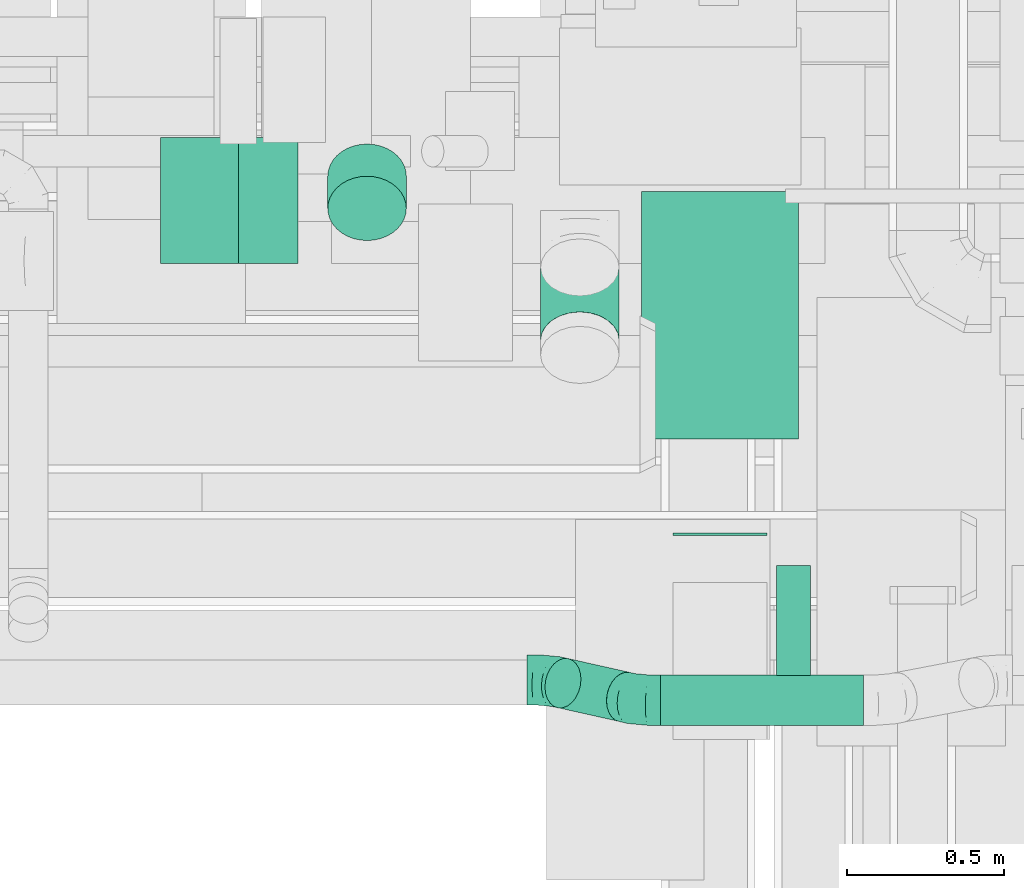
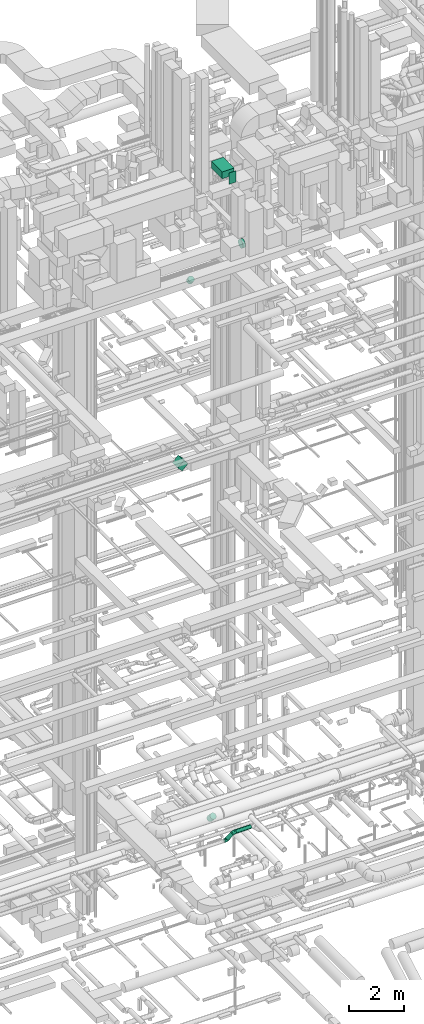
# One storey, part 180 of 337: 8 flow segments, 2 flow fittings.
"""IFC2X3 building model written with IfcOpenShell, lengths in millimetres."""

from ifc_helpers import new_model, entity, si_unit, converted_unit, derived_unit, direction, frame, frame_2d, origin, origin_2d_with_axis, place, context, subcontext, project, spatial, rectangle, circle, extrude, faceted_brep, source, transform, mapped, material, type_object, type_shapes, element, save


model = new_model("IFC2X3")

# Units and contexts
model_context = context("Model", 3, precision=0.01, world=origin(), true_north=direction((6.12303176911189e-17, 1.0)))
body_context = subcontext(model_context, "Body", "Model", "MODEL_VIEW")
ifc_project = project(units=[si_unit("LENGTHUNIT", "METRE", prefix="MILLI"), si_unit("AREAUNIT", "SQUARE_METRE"), si_unit("VOLUMEUNIT", "CUBIC_METRE"), converted_unit("PLANEANGLEUNIT", "DEGREE", entity("IfcRatioMeasure", 0.0174532925199433), si_unit("PLANEANGLEUNIT", "RADIAN"), dimensions=[0, 0, 0, 0, 0, 0, 0]), si_unit("MASSUNIT", "GRAM", prefix="KILO"), derived_unit("MASSDENSITYUNIT", [(si_unit("MASSUNIT", "GRAM", prefix="KILO"), 1), (si_unit("LENGTHUNIT", "METRE"), -3)]), derived_unit("MOMENTOFINERTIAUNIT", [(si_unit("LENGTHUNIT", "METRE"), 4)]), si_unit("TIMEUNIT", "SECOND"), si_unit("FREQUENCYUNIT", "HERTZ"), si_unit("THERMODYNAMICTEMPERATUREUNIT", "DEGREE_CELSIUS"), derived_unit("THERMALTRANSMITTANCEUNIT", [(si_unit("MASSUNIT", "GRAM", prefix="KILO"), 1), (si_unit("THERMODYNAMICTEMPERATUREUNIT", "KELVIN"), -1), (si_unit("TIMEUNIT", "SECOND"), -3)]), derived_unit("VOLUMETRICFLOWRATEUNIT", [(si_unit("LENGTHUNIT", "METRE"), 3), (si_unit("TIMEUNIT", "SECOND"), -1)]), derived_unit("MASSFLOWRATEUNIT", [(si_unit("MASSUNIT", "GRAM", prefix="KILO"), 1), (si_unit("TIMEUNIT", "SECOND"), -1)]), derived_unit("ROTATIONALFREQUENCYUNIT", [(si_unit("TIMEUNIT", "SECOND"), -1)]), si_unit("ELECTRICCURRENTUNIT", "AMPERE"), si_unit("ELECTRICVOLTAGEUNIT", "VOLT"), si_unit("POWERUNIT", "WATT"), si_unit("FORCEUNIT", "NEWTON", prefix="KILO"), si_unit("ILLUMINANCEUNIT", "LUX"), si_unit("LUMINOUSFLUXUNIT", "LUMEN"), si_unit("LUMINOUSINTENSITYUNIT", "CANDELA"), derived_unit("USERDEFINED", [(si_unit("MASSUNIT", "GRAM", prefix="KILO"), -1), (si_unit("LENGTHUNIT", "METRE"), -2), (si_unit("TIMEUNIT", "SECOND"), 3), (si_unit("LUMINOUSFLUXUNIT", "LUMEN"), 1)]), derived_unit("LINEARVELOCITYUNIT", [(si_unit("LENGTHUNIT", "METRE"), 1), (si_unit("TIMEUNIT", "SECOND"), -1)]), si_unit("PRESSUREUNIT", "PASCAL"), derived_unit("USERDEFINED", [(si_unit("LENGTHUNIT", "METRE"), -2), (si_unit("MASSUNIT", "GRAM", prefix="KILO"), 1), (si_unit("TIMEUNIT", "SECOND"), -2)]), derived_unit("LINEARFORCEUNIT", [(si_unit("MASSUNIT", "GRAM", prefix="KILO"), 1), (si_unit("LENGTHUNIT", "METRE"), 1), (si_unit("TIMEUNIT", "SECOND"), -2), (si_unit("LENGTHUNIT", "METRE"), -1)]), derived_unit("PLANARFORCEUNIT", [(si_unit("MASSUNIT", "GRAM", prefix="KILO"), 1), (si_unit("LENGTHUNIT", "METRE"), 1), (si_unit("TIMEUNIT", "SECOND"), -2), (si_unit("LENGTHUNIT", "METRE"), -2)])], contexts=[model_context])

# Site, building, storey
site_placement = place(None, origin())
site = spatial("IfcSite", under=ifc_project, at=site_placement, CompositionType="ELEMENT")
building_placement = place(site_placement, origin())
building = spatial("IfcBuilding", under=site, at=building_placement, CompositionType="ELEMENT")
storey_placement = place(building_placement, origin())
storey = spatial("IfcBuildingStorey", under=building, at=storey_placement, CompositionType="ELEMENT", Elevation=0.0)

# Flow segments
duct_segment_type_1 = type_object("IfcDuctSegmentType", PredefinedType="NOTDEFINED")
flow_segment_1_placement = place(storey_placement, frame((47985.48, 9525.31, 18766.45)))
element("IfcFlowSegment", 1, at=flow_segment_1_placement, inside=storey, type_object=duct_segment_type_1, context=body_context, shape_type="SweptSolid", body=[
    extrude(rectangle(XDim=350.0, YDim=268.162338159304, at=frame_2d((0.0, 0.0), x_axis=(0.0, 1.0))), frame((218.55, 0.0, 218.55), z_axis=(0.0, 1.0, 0.0), x_axis=(0.707106781186604, 0.0, -0.707106781186491)), (0.0, 0.0, 1.0), 400.0),
])
flow_segment_2_placement = place(storey_placement, frame((49515.11, 8966.84, 31500.0)))
element("IfcFlowSegment", 2, at=flow_segment_2_placement, inside=storey, type_object=duct_segment_type_1, context=body_context, shape_type="SweptSolid", body=[
    extrude(rectangle(XDim=787.000000000107, YDim=499.999999999999, at=origin_2d_with_axis()), frame((250.0, 393.5, 0.0), z_axis=(0.0, 0.0, 1.0), x_axis=(0.0, 1.0, 0.0)), (0.0, 0.0, 1.0), 300.000000000001),
])
flow_segment_3_placement = place(storey_placement, frame((49615.11, 8660.0, 31400.0)))
element("IfcFlowSegment", 3, at=flow_segment_3_placement, inside=storey, type_object=duct_segment_type_1, context=body_context, shape_type="SweptSolid", body=[
    extrude(rectangle(XDim=6.83947999997308, YDim=300.000000000001, at=origin_2d_with_axis()), frame((150.0, 3.42, 0.0), z_axis=(0.0, 0.0, 1.0), x_axis=(0.0, -1.0, 0.0)), (0.0, 0.0, 1.0), 499.999999999999),
])
duct_segment_type_2 = type_object("IfcDuctSegmentType", PredefinedType="NOTDEFINED")
flow_segment_4_placement = place(storey_placement, frame((49945.11, 8212.96, 28660.93)))
element("IfcFlowSegment", 4, at=flow_segment_4_placement, inside=storey, type_object=duct_segment_type_2, context=body_context, shape_type="SweptSolid", body=[
    extrude(circle(Radius=175.0, at=origin_2d_with_axis()), frame((0.0, 176.6, 176.6), z_axis=(1.0, 0.0, 0.0), x_axis=(0.0, 1.0, 0.0)), (0.0, 0.0, 1.0), 108.499999999984),
])
flow_segment_5_placement = place(storey_placement, frame((49575.99, 8053.41, 3158.45)))
element("IfcFlowSegment", 5, at=flow_segment_5_placement, inside=storey, type_object=duct_segment_type_2, context=body_context, shape_type="SweptSolid", body=[
    extrude(circle(Radius=80.0, at=origin_2d_with_axis()), frame((0.0, 81.53, 81.53), z_axis=(1.0, 0.0, 0.0), x_axis=(0.0, 0.975789577016006, 0.218711456917383)), (0.0, 0.0, 1.0), 645.577680492958),
])
flow_segment_6_placement = place(storey_placement, frame((49206.81, 8065.42, 2938.3)))
element("IfcFlowSegment", 6, at=flow_segment_6_placement, inside=storey, type_object=duct_segment_type_2, context=body_context, shape_type="SweptSolid", body=[
    extrude(circle(Radius=80.0, at=origin_2d_with_axis()), frame((58.85, 124.05, 58.78), z_axis=(0.698389788270617, -0.156535642198603, 0.698389788270701), x_axis=(0.0, -0.975789577016007, -0.218711456917377)), (0.0, 0.0, 1.0), 280.389849611387),
])
flow_segment_7_placement = place(storey_placement, frame((49192.74, 9187.1, 2990.83)))
element("IfcFlowSegment", 7, at=flow_segment_7_placement, inside=storey, type_object=duct_segment_type_2, context=body_context, shape_type="SweptSolid", body=[
    extrude(circle(Radius=125.0, at=origin_2d_with_axis()), frame((126.6, 92.44, 333.61), z_axis=(0.0, 0.686859009625245, -0.726790685752527), x_axis=(1.0, 0.0, 0.0)), (0.0, 0.0, 1.0), 338.695344060888),
])
flow_segment_8_placement = place(storey_placement, frame((48515.73, 9596.09, 26731.09)))
element("IfcFlowSegment", 8, at=flow_segment_8_placement, inside=storey, type_object=duct_segment_type_2, context=body_context, shape_type="SweptSolid", body=[
    extrude(circle(Radius=125.0, at=origin_2d_with_axis()), frame((126.6, 103.87, 219.38), z_axis=(0.0, 0.574936968585454, -0.818197703586223), x_axis=(0.0, 0.818197703586223, 0.574936968585454)), (0.0, 0.0, 1.0), 178.334819540636),
])

# Flow fittings
ifc_material = material()
duct_fitting_type = type_object("IfcDuctFittingType", PredefinedType="NOTDEFINED", material=ifc_material)
shared_shape = source(origin(), body_context, "Body", "Brep", [
    faceted_brep([(-67.43, 0.0, -80.0), (-67.43, -20.71, -77.27), (-67.43, -40.0, -69.28), (-67.43, -56.57, -56.57), (-67.43, -69.28, -40.0), (-67.43, -77.27, -20.71), (-67.43, -80.0, 0.0), (-67.43, -77.27, 20.71), (-67.43, -69.28, 40.0), (-67.43, -56.57, 56.57), (-67.43, -40.0, 69.28), (-67.43, -20.71, 77.27), (-67.43, 0.0, 80.0), (-67.43, 20.71, 77.27), (-67.43, 40.0, 69.28), (-67.43, 56.57, 56.57), (-67.43, 69.28, 40.0), (-67.43, 77.27, 20.71), (-67.43, 80.0, 0.0), (-67.43, 77.27, -20.71), (-67.43, 69.28, -40.0), (-67.43, 56.57, -56.57), (-67.43, 40.0, -69.28), (-67.43, 20.71, -77.27), (-39.27, 20.71, 77.27), (-43.17, 40.0, 69.28), (-35.09, 0.0, 80.0), (-46.52, 56.57, 56.57), (-50.71, 77.27, 20.71), (-51.26, 80.0, 0.0), (-49.09, 69.28, 40.0), (-49.09, 69.28, -40.0), (-46.52, 56.57, -56.57), (-50.71, 77.27, -20.71), (-39.27, 20.71, -77.27), (-35.09, 0.0, -80.0), (-43.17, 40.0, -69.28), (-30.91, -20.71, -77.27), (-27.01, -40.0, -69.28), (-23.66, -56.57, -56.57), (-21.09, -69.28, -40.0), (-19.47, -77.27, -20.71), (-18.92, -80.0, 0.0), (-19.47, -77.27, 20.71), (-21.09, -69.28, 40.0), (-23.66, -56.57, 56.57), (-27.01, -40.0, 69.28), (-30.91, -20.71, 77.27), (12.61, 42.57, 77.27), (1.52, 58.84, 69.28), (24.51, 25.11, 80.0), (-8.0, 72.8, 56.57), (-15.3, 83.52, 40.0), (-19.89, 90.26, 20.71), (-21.46, 92.56, 0.0), (-19.89, 90.26, -20.71), (-15.3, 83.52, -40.0), (-8.0, 72.8, -56.57), (12.61, 42.57, -77.27), (24.51, 25.11, -80.0), (1.52, 58.84, -69.28), (36.4, 7.66, -77.27), (47.49, -8.61, -69.28), (57.01, -22.57, -56.57), (64.31, -33.29, -40.0), (68.91, -40.03, -20.71), (70.47, -42.33, 0.0), (68.91, -40.03, 20.71), (64.31, -33.29, 40.0), (57.01, -22.57, 56.57), (47.49, -8.61, 69.28), (36.4, 7.66, 77.27), (47.09, 48.26, 80.0), (32.27, 62.72, 77.27), (18.46, 76.19, 69.28), (6.6, 87.76, 56.57), (-2.5, 96.64, 40.0), (-8.22, 102.23, 20.71), (-10.17, 104.13, 0.0), (-8.22, 102.23, -20.71), (-2.5, 96.64, -40.0), (6.6, 87.76, -56.57), (18.46, 76.19, -69.28), (32.27, 62.72, -77.27), (47.09, 48.26, -80.0), (61.91, 33.8, -77.27), (75.72, 20.32, -69.28), (87.58, 8.75, -56.57), (96.68, -0.13, -40.0), (102.4, -5.71, -20.71), (104.35, -7.61, 0.0), (102.4, -5.71, 20.71), (96.68, -0.13, 40.0), (87.58, 8.75, 56.57), (61.91, 33.8, 77.27), (75.72, 20.32, 69.28)], [[[0, 1, 2, 3, 4, 5, 6, 7, 8, 9, 10, 11, 12, 13, 14, 15, 16, 17, 18, 19, 20, 21, 22, 23]], [[24, 25, 14, 13]], [[26, 24, 13, 12]], [[14, 25, 27, 15]], [[28, 29, 18, 17]], [[30, 28, 17, 16]], [[15, 27, 30, 16]], [[20, 31, 32, 21]], [[33, 31, 20, 19]], [[18, 29, 33, 19]], [[34, 35, 0, 23]], [[36, 34, 23, 22]], [[32, 36, 22, 21]], [[2, 1, 37, 38]], [[3, 2, 38, 39]], [[0, 35, 37, 1]], [[5, 4, 40, 41]], [[6, 5, 41, 42]], [[3, 39, 40, 4]], [[6, 42, 43, 7]], [[7, 43, 44, 8]], [[8, 44, 45, 9]], [[10, 46, 47, 11]], [[11, 47, 26, 12]], [[9, 45, 46, 10]], [[48, 49, 25, 24]], [[50, 48, 24, 26]], [[27, 25, 49, 51]], [[52, 53, 28, 30]], [[51, 52, 30, 27]], [[29, 28, 53, 54]], [[55, 56, 31, 33]], [[54, 55, 33, 29]], [[32, 31, 56, 57]], [[58, 59, 35, 34]], [[60, 58, 34, 36]], [[57, 60, 36, 32]], [[37, 35, 59, 61]], [[38, 37, 61, 62]], [[39, 38, 62, 63]], [[41, 40, 64, 65]], [[42, 41, 65, 66]], [[63, 64, 40, 39]], [[43, 42, 66, 67]], [[44, 43, 67, 68]], [[68, 69, 45, 44]], [[46, 45, 69, 70]], [[47, 46, 70, 71]], [[26, 47, 71, 50]], [[48, 50, 72, 73]], [[49, 48, 73, 74]], [[51, 49, 74, 75]], [[53, 52, 76, 77]], [[54, 53, 77, 78]], [[51, 75, 76, 52]], [[54, 78, 79, 55]], [[55, 79, 80, 56]], [[56, 80, 81, 57]], [[60, 82, 83, 58]], [[58, 83, 84, 59]], [[60, 57, 81, 82]], [[59, 84, 85, 61]], [[61, 85, 86, 62]], [[62, 86, 87, 63]], [[64, 88, 89, 65]], [[65, 89, 90, 66]], [[63, 87, 88, 64]], [[67, 66, 90, 91]], [[68, 67, 91, 92]], [[69, 68, 92, 93]], [[94, 72, 50, 71]], [[95, 94, 71, 70]], [[93, 95, 70, 69]], [[83, 82, 81, 80, 79, 78, 77, 76, 75, 74, 73, 72, 94, 95, 93, 92, 91, 90, 89, 88, 87, 86, 85, 84]]]),
])
type_shapes(duct_fitting_type, [shared_shape])
for number, where, z_axis, x_axis in (
    (9, (49218.57, 8200.02, 2950.0), (0.0, -0.975789577016008, -0.218711456917375), (1.0, 0.0, 0.0)),
    (10, (49508.57, 8134.94, 3239.98), (0.0, -0.975789577016006, -0.218711456917382), (-1.0, 0.0, 0.0)),
):
    element("IfcFlowFitting", number, at=place(storey_placement, frame(where, z_axis=z_axis, x_axis=x_axis)), inside=storey, type_object=duct_fitting_type, material=ifc_material, context=body_context, shape_type="MappedRepresentation", body=[
        mapped(shared_shape, transform((0.0, 0.0, 0.0), scale=1.0)),
    ])

save(model, "model.ifc")
